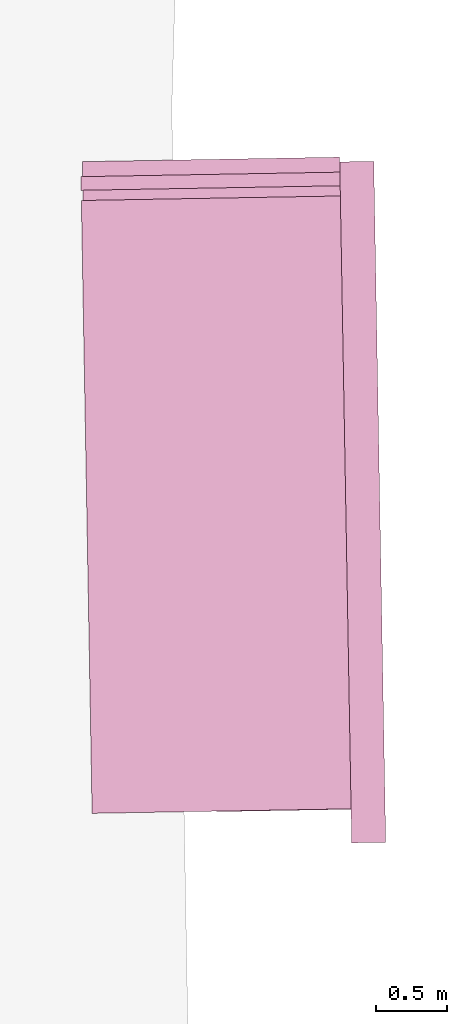
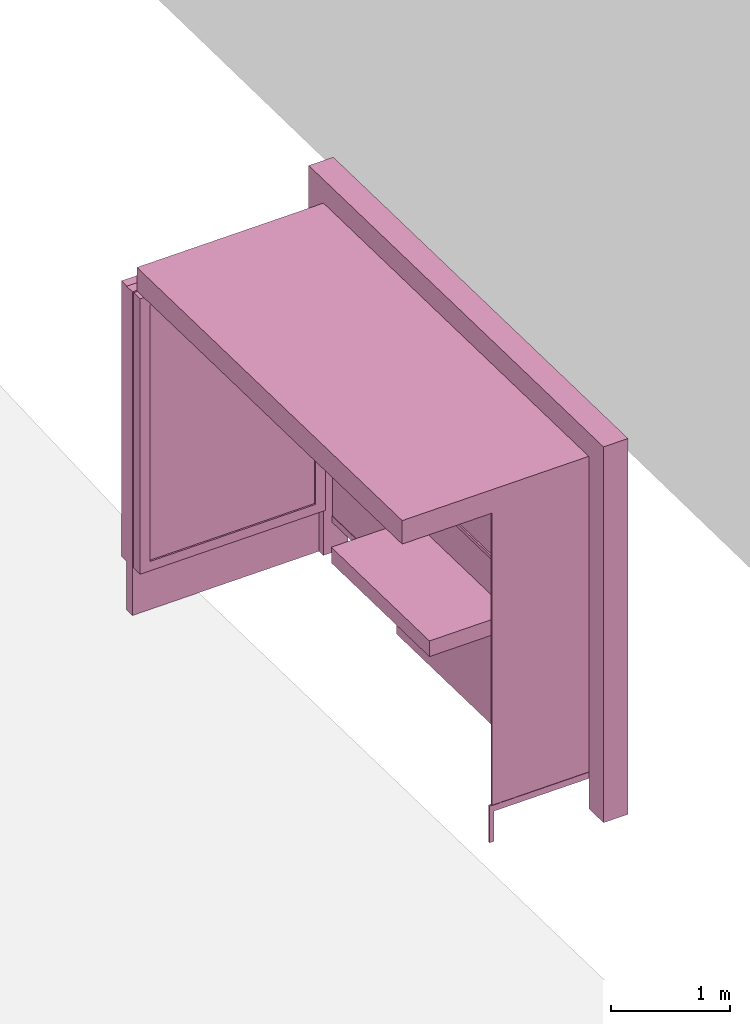
# One storey, part 27 of 200: 1 furnishing.
"""IFC4 building model written with IfcOpenShell, lengths in metres."""

from ifc_helpers import new_model, si_unit, origin_with_axes, place, context, subcontext, project, spatial, triangles, material, element, save


model = new_model("IFC4")

# Units and contexts
model_context = context("Model", 3, precision=1e-05, world=origin_with_axes())
body_context = subcontext(model_context, "Body", "Model", "MODEL_VIEW")
ifc_project = project(units=[si_unit("VOLUMEUNIT", "CUBIC_METRE"), si_unit("LENGTHUNIT", "METRE"), si_unit("AREAUNIT", "SQUARE_METRE")], contexts=[model_context])

# Site, building, storey
site_placement = place(None, origin_with_axes())
site = spatial("IfcSite", under=ifc_project, at=site_placement)
building_placement = place(site_placement, origin_with_axes())
building = spatial("IfcBuilding", under=site, at=building_placement, Name="Building")
storey_placement = place(building_placement, origin_with_axes())
storey = spatial("IfcBuildingStorey", under=building, at=storey_placement, Name="Ground")

# Furnishing
ifc_material = material(Name="busStop")
furnishing_placement = place(storey_placement, origin_with_axes())
element("IfcFurnishingElement", 1, at=furnishing_placement, inside=storey, material=ifc_material, Name="cw_instances_busStop_22", context=body_context, shape_type="Tessellation", body=[
    triangles([(180.32204936237486, -389.8630590428652, 3.3823837170154), (182.47203148521953, -394.1644852282058, 3.3823837170154), (182.3960797844333, -389.8267450546434, 3.3823837170154), (180.39800085740129, -394.2007993968073, 3.3823837170154), (180.32204926598064, -389.86305904455304, 3.623406387340317), (182.4720313888253, -394.16448522989367, 3.623406387340317), (180.39800076100704, -394.2007993984952, 3.623406387340317), (182.3960796880391, -389.8267450563313, 3.623406387340317), (180.32204936237486, -389.8630590428652, 3.3823837170154), (180.39800076100704, -394.2007993984952, 3.623406387340317), (180.39800085740129, -394.2007993968073, 3.3823837170154), (180.32204926598064, -389.86305904455304, 3.623406387340317), (180.39800085740129, -394.2007993968073, 3.3823837170154), (182.4720313888253, -394.16448522989367, 3.623406387340317), (182.47203148521953, -394.1644852282058, 3.3823837170154), (180.39800076100704, -394.2007993984952, 3.623406387340317), (182.47203148521953, -394.1644852282058, 3.3823837170154), (182.3960796880391, -389.8267450563313, 3.623406387340317), (182.3960797844333, -389.8267450546434, 3.3823837170154), (182.4720313888253, -394.16448522989367, 3.623406387340317), (182.3960797844333, -389.8267450546434, 3.3823837170154), (180.32204926598064, -389.86305904455304, 3.623406387340317), (180.32204936237486, -389.8630590428652, 3.3823837170154), (182.3960796880391, -389.8267450563313, 3.623406387340317), (182.15509378013567, -389.8309646539405, 3.864428655961051), (182.39185972401305, -389.58575933162064, 3.864428655961051), (182.39607931852788, -389.8267450628013, 3.864428655961051), (182.15087418562084, -389.5899789227598, 3.864428655961051), (182.15509378013567, -389.8309646539405, 3.623406387340317), (182.15087418562084, -389.5899789227598, 3.864428655961051), (182.15509378013567, -389.8309646539405, 3.864428655961051), (182.15087418562084, -389.5899789227598, 3.623406387340317), (182.23526486292556, -394.4096903534864, 3.623406387340317), (182.47625059410623, -394.40547075897155, 3.864428655961051), (182.47625059410623, -394.40547075897155, 3.623406387340317), (182.23526486292556, -394.4096903534864, 3.864428655961051), (182.4720310032484, -394.164485236645, 3.623406387340317), (182.47625059410623, -394.40547075897155, 3.864428655961051), (182.4720310032484, -394.164485236645, 3.864428655961051), (182.47625059410623, -394.40547075897155, 3.623406387340317), (182.3918599007358, -389.58575932852625, 3.623406387340317), (182.15087418562084, -389.5899789227598, 3.864428655961051), (182.15087418562084, -389.5899789227598, 3.623406387340317), (182.39185972401305, -389.58575933162064, 3.864428655961051), (182.23104546485618, -394.1687048277842, 3.864428655961051), (182.4720310032484, -394.164485236645, 3.864428655961051), (182.23104546485618, -394.1687048277842, 3.623406387340317), (182.23104546485618, -394.1687048277842, 3.864428655961051), (182.3918599007358, -389.58575932852625, 3.623406387340317), (182.39607931852788, -389.8267450628013, 3.864428655961051), (182.39185972401305, -389.58575933162064, 3.864428655961051), (182.39607931852788, -389.8267450628013, 3.623406387340317), (182.23526486292556, -394.4096903534864, 3.864428655961051), (182.47625059410623, -394.40547075897155, 3.864428655961051), (182.23526486292556, -394.4096903534864, 3.623406387340317), (182.23526486292556, -394.4096903534864, 3.864428655961051), (182.39186076828386, -389.58575931333576, 9.480218712634252e-07), (182.15087532628587, -389.5899789027871, 8.998173693347766e-07), (182.3960803627987, -389.82674504451643, 9.480218712634252e-07), (182.39186076828386, -389.58575931333576, 9.480218712634252e-07), (182.39607931852788, -389.8267450628013, 3.623406387340317), (182.15509474407796, -389.8309646370621, 8.998173693347766e-07), (182.15509378013567, -389.8309646539405, 3.623406387340317), (182.3960803627987, -389.82674504451643, 9.480218712634252e-07), (182.15087532628587, -389.5899789027871, 8.998173693347766e-07), (182.15509474407796, -389.8309646370621, 8.998173693347766e-07), (182.23526599293223, -394.4096888069904, 8.998173693347766e-07), (182.47625163837705, -394.40547074068667, 9.480218712634252e-07), (182.23104640179307, -394.16870326859816, 8.998173693347766e-07), (182.23526599293223, -394.4096888069904, 8.998173693347766e-07), (182.23104546485618, -394.1687048277842, 3.623406387340317), (182.4720320205138, -394.1644836760525, 9.480218712634252e-07), (182.4720310032484, -394.164485236645, 3.623406387340317), (182.23104640179307, -394.16870326859816, 8.998173693347766e-07), (182.47625163837705, -394.40547074068667, 9.480218712634252e-07), (182.4720320205138, -394.1644836760525, 9.480218712634252e-07), (181.279848137964, -394.1851094445589, 0.34596862720110877), (182.3258808533353, -394.1667936966244, 3.3823837170154), (182.32588172088333, -394.16679368143383, 0.34596880395094914), (181.27984735074446, -394.1851094583429, 3.3823837170154), (182.32560041505118, -394.150727992798, 0.34596880395094914), (181.27956604491231, -394.169043769707, 3.3823837170154), (181.27956683213185, -394.16904375592304, 0.34596862720110877), (182.32559954750315, -394.1507280079885, 3.3823837170154), (181.27956683213185, -394.16904375592304, 0.34596862720110877), (181.27984735074446, -394.1851094583429, 3.3823837170154), (181.279848137964, -394.1851094445589, 0.34596862720110877), (181.27956604491231, -394.169043769707, 3.3823837170154), (182.325530086835, -394.14671147022835, 0.31383250146818464), (181.27991851100163, -394.18912577349613, 0.3138323086501769), (182.32595204572388, -394.170810011215, 0.31383250146818464), (181.27949655211276, -394.1650272325095, 0.3138323086501769), (182.325530086835, -394.14671147022835, 0.378105122501881), (181.2799184949359, -394.18912577377745, 0.3781049296838733), (181.27949653604705, -394.1650272327908, 0.3781049296838733), (182.32595204572388, -394.170810011215, 0.378105122501881), (182.325530086835, -394.14671147022835, 0.31383250146818464), (181.27949653604705, -394.1650272327908, 0.3781049296838733), (181.27949655211276, -394.1650272325095, 0.3138323086501769), (182.325530086835, -394.14671147022835, 0.378105122501881), (181.27991851100163, -394.18912577349613, 0.3138323086501769), (182.32595204572388, -394.170810011215, 0.378105122501881), (182.32595204572388, -394.170810011215, 0.31383250146818464), (181.2799184949359, -394.18912577377745, 0.3781049296838733), (181.2799184949359, -394.18912577377745, 0.3781049296838733), (181.27949655211276, -394.1650272325095, 0.3138323086501769), (181.27949653604705, -394.1650272327908, 0.3781049296838733), (181.27991851100163, -394.18912577349613, 0.3138323086501769), (181.25743921817025, -394.16914498649095, 0.3781049296838733), (181.30197565418732, -394.1850063032973, 0.3781049296838733), (181.25773051065073, -394.18578102370947, 0.3781049296838733), (181.30168436170686, -394.16837026607885, 0.3781049296838733), (181.25743947522153, -394.1691449819901, 1.446135057859462e-07), (181.25773051065073, -394.18578102370947, 0.3781049296838733), (181.25773076770201, -394.18578101920855, 1.446135057859462e-07), (181.25743921817025, -394.16914498649095, 0.3781049296838733), (181.25773076770201, -394.18578101920855, 1.446135057859462e-07), (181.30197565418732, -394.1850063032973, 0.3781049296838733), (181.30197576664727, -394.1850063013282, 1.606816730954958e-07), (181.25773051065073, -394.18578102370947, 0.3781049296838733), (181.30197576664727, -394.1850063013282, 1.606816730954958e-07), (181.30168436170686, -394.16837026607885, 0.3781049296838733), (181.3016844741668, -394.1683702641097, 1.606816730954958e-07), (181.30197565418732, -394.1850063032973, 0.3781049296838733), (181.3016844741668, -394.1683702641097, 1.606816730954958e-07), (181.25743921817025, -394.16914498649095, 0.3781049296838733), (181.25743947522153, -394.1691449819901, 1.446135057859462e-07), (181.30168436170686, -394.16837026607885, 0.3781049296838733), (182.11214955591205, -391.13838923568755, 1.1247720651681516), (182.29368144399288, -392.7422736912719, 1.1247721615771553), (182.14027968528606, -392.7449597142843, 1.1247720651681516), (182.2655511218304, -391.1357032160509, 1.1247721615771553), (182.14027987807452, -392.74495971090863, 4.98113186596037e-07), (182.11214955591205, -391.13838923568755, 0.9640904563453251), (182.14027968528606, -392.7449597142843, 0.9640904563453251), (182.11214989329184, -391.13838922978016, 4.98113186596037e-07), (182.2936818295698, -392.74227368452057, 5.302495212151362e-07), (182.14027968528606, -392.7449597142843, 0.9640904563453251), (182.29368144399288, -392.7422736912719, 0.9640905527543289), (182.14027987807452, -392.74495971090863, 4.98113186596037e-07), (182.2655515074073, -391.13570320929955, 5.302495212151362e-07), (182.29368144399288, -392.7422736912719, 0.9640905527543289), (182.2655511218304, -391.1357032160509, 0.9640905527543289), (182.2936818295698, -392.74227368452057, 5.302495212151362e-07), (182.11214989329184, -391.13838922978016, 4.98113186596037e-07), (182.2655511218304, -391.1357032160509, 0.9640905527543289), (182.11214955591205, -391.13838923568755, 0.9640904563453251), (182.2655515074073, -391.13570320929955, 5.302495212151362e-07), (181.49765156148587, -392.75621195769713, 1.1247719687591475), (181.46952135178333, -391.14964148050694, 0.9640903599363211), (181.46952131965193, -391.1496414810696, 1.1247719687591475), (181.49765157755158, -392.7562119574158, 0.9640903599363211), (182.29368144399288, -392.7422736912719, 1.1247721615771553), (182.14027968528606, -392.7449597142843, 1.1247720651681516), (182.2655511218304, -391.1357032160509, 1.1247721615771553), (182.29368144399288, -392.7422736912719, 1.1247721615771553), (182.11214955591205, -391.13838923568755, 1.1247720651681516), (182.2655511218304, -391.1357032160509, 1.1247721615771553), (181.46952131965193, -391.1496414810696, 1.1247719687591475), (181.49765156148587, -392.75621195769713, 1.1247719687591475), (181.46952135178333, -391.14964148050694, 0.9640903599363211), (181.46952131965193, -391.1496414810696, 1.1247719687591475), (181.49765156148587, -392.75621195769713, 1.1247719687591475), (181.49765157755158, -392.7562119574158, 0.9640903599363211), (182.23945658003586, -389.6898030603369, 0.34596880395094914), (182.31996210403832, -394.2876777131457, 3.5028950521778586), (182.3199630519149, -394.2876776965486, 0.34596880395094914), (182.23945590527626, -389.68980307215173, 3.5028950521778586), (182.33602875661646, -394.28739639043516, 0.34596880395094914), (182.25552159391214, -389.6895217663196, 3.5028950521778586), (182.2555222686717, -389.68952175450477, 0.34596880395094914), (182.33602779267417, -394.28739640731357, 3.5028950521778586), (182.05416985039662, -389.5738965455137, 0.5809565598614106), (180.4261684049268, -389.6024024073994, 3.219113622848009), (180.42616898329217, -389.60240239727233, 0.5809562706343991), (182.05416923989986, -389.57389655620335, 3.219113622848009), (182.15028277277392, -389.55614302019717, 0.48454753993594585), (180.42588767746003, -389.5863367086365, 0.5809562706343991), (180.32949351892074, -389.5880230173874, 0.48454721857259964), (182.05388854456447, -389.55783085687784, 0.5809565598614106), (180.42588709909467, -389.5863367187635, 3.219113622848009), (180.32949267809676, -389.5880245588199, 3.3155225302963025), (182.05388793406772, -389.5578308675675, 3.219113622848009), (182.15028211408003, -389.5561430317307, 3.3155225302963025), (182.05388854456447, -389.55783085687784, 0.5809565598614106), (180.42616898329217, -389.60240239727233, 0.5809562706343991), (180.42588767746003, -389.5863367086365, 0.5809562706343991), (182.05416985039662, -389.5738965455137, 0.5809565598614106), (180.42588767746003, -389.5863367086365, 0.5809562706343991), (180.4261684049268, -389.6024024073994, 3.219113622848009), (180.42588709909467, -389.5863367187635, 3.219113622848009), (180.42616898329217, -389.60240239727233, 0.5809562706343991), (180.42588709909467, -389.5863367187635, 3.219113622848009), (182.05416923989986, -389.57389655620335, 3.219113622848009), (182.05388793406772, -389.5578308675675, 3.219113622848009), (180.4261684049268, -389.6024024073994, 3.219113622848009), (182.05388793406772, -389.5578308675675, 3.219113622848009), (182.05416985039662, -389.5738965455137, 0.5809565598614106), (182.05388854456447, -389.55783085687784, 0.5809565598614106), (182.05416923989986, -389.57389655620335, 3.219113622848009), (180.334897186847, -389.89668205855605, 3.3155225302963025), (182.15028211408003, -389.5561430317307, 3.3155225302963025), (182.1556863336476, -389.8648005365304, 3.3155225302963025), (180.32949267809676, -389.5880245588199, 3.3155225302963025), (180.33489805439507, -389.89668204336556, 0.48454721857259964), (180.32949267809676, -389.5880245588199, 3.3155225302963025), (180.334897186847, -389.89668205855605, 3.3155225302963025), (180.32949351892074, -389.5880230173874, 0.48454721857259964), (182.15028277277392, -389.55614302019717, 0.48454753993594585), (182.1556863336476, -389.8648005365304, 3.3155225302963025), (182.15028211408003, -389.5561430317307, 3.3155225302963025), (182.15568710480142, -389.8648005230277, 0.48454753993594585), (182.05901160289125, -389.85042267050994, 0.5809565598614106), (180.43101030201277, -389.8789285298638, 3.219113622848009), (182.059010799606, -389.8504226845752, 3.219113622848009), (180.43101088037812, -389.8789285197368, 0.5809562706343991), (182.15568710480142, -389.8648005230277, 0.48454753993594585), (180.43129218621027, -389.8949942083727, 0.5809562706343991), (182.0592929087234, -389.8664883591458, 0.5809565598614106), (180.33489805439507, -389.89668204336556, 0.48454721857259964), (180.4312916078449, -389.8949942184997, 3.219113622848009), (180.334897186847, -389.89668205855605, 3.3155225302963025), (182.05929210543815, -389.8664883732111, 3.219113622848009), (182.1556863336476, -389.8648005365304, 3.3155225302963025), (182.0592929087234, -389.8664883591458, 0.5809565598614106), (180.43101088037812, -389.8789285197368, 0.5809562706343991), (182.05901160289125, -389.85042267050994, 0.5809565598614106), (180.43129218621027, -389.8949942083727, 0.5809562706343991), (180.43129218621027, -389.8949942083727, 0.5809562706343991), (180.43101030201277, -389.8789285298638, 3.219113622848009), (180.43101088037812, -389.8789285197368, 0.5809562706343991), (180.4312916078449, -389.8949942184997, 3.219113622848009), (180.4312916078449, -389.8949942184997, 3.219113622848009), (182.059010799606, -389.8504226845752, 3.219113622848009), (180.43101030201277, -389.8789285298638, 3.219113622848009), (182.05929210543815, -389.8664883732111, 3.219113622848009), (182.05929210543815, -389.8664883732111, 3.219113622848009), (182.05901160289125, -389.85042267050994, 0.5809565598614106), (182.059010799606, -389.8504226845752, 3.219113622848009), (182.0592929087234, -389.8664883591458, 0.5809565598614106), (180.31909567772075, -389.69437083039765, 3.328512133158346), (182.1538282859516, -389.7586688475064, 3.328512133158346), (180.32078348598955, -389.790763435971, 3.328512133158346), (182.1521404509587, -389.6622747156912, 3.328512133158346), (180.3190963223806, -389.69436909955243, 0.0), (180.32078348598955, -389.790763435971, 3.328512133158346), (180.32078416074916, -389.79076342415607, 0.0), (180.31909567772075, -389.69437083039765, 3.328512133158346), (180.32078416074916, -389.79076342415607, 0.0), (182.1538282859516, -389.7586688475064, 3.328512133158346), (182.15382904103973, -389.758668834285, 5.141813539055866e-07), (180.32078348598955, -389.790763435971, 3.328512133158346), (182.15382904103973, -389.758668834285, 5.141813539055866e-07), (182.1521404509587, -389.6622747156912, 3.328512133158346), (182.15214120604685, -389.6622747024698, 5.141813539055866e-07), (182.1538282859516, -389.7586688475064, 3.328512133158346), (182.15214120604685, -389.6622747024698, 5.141813539055866e-07), (180.31909567772075, -389.69437083039765, 3.328512133158346), (180.3190963223806, -389.69436909955243, 0.0), (182.1521404509587, -389.6622747156912, 3.328512133158346), (182.23544015386045, -389.68987338686526, 0.31383250146818464), (182.33830344464042, -394.1878488737557, 0.31383250146818464), (182.25953879124134, -389.68945142628854, 0.31383250146818464), (182.31420491971946, -394.1882708323633, 0.31383250146818464), (182.23544015386045, -389.68987338686526, 0.378105122501881), (182.33830344464042, -394.1878488737557, 0.378105122501881), (182.31420491971946, -394.1882708323633, 0.378105122501881), (182.25953879124134, -389.68945142628854, 0.378105122501881), (182.23544015386045, -389.68987338686526, 0.31383250146818464), (182.31420491971946, -394.1882708323633, 0.378105122501881), (182.31420491971946, -394.1882708323633, 0.31383250146818464), (182.23544015386045, -389.68987338686526, 0.378105122501881), (182.33830344464042, -394.1878488737557, 0.31383250146818464), (182.25953879124134, -389.68945142628854, 0.378105122501881), (182.25953879124134, -389.68945142628854, 0.31383250146818464), (182.33830344464042, -394.1878488737557, 0.378105122501881), (182.2674541977584, -391.29637667877864, 1.5289466322217304), (182.28995801235624, -392.58163308278523, 2.8143998402358568), (182.2674538121815, -391.29637668553, 2.8143998402358568), (182.28995839793313, -392.5816330760339, 1.5289466322217304), (182.25451257332554, -391.32874455975815, 1.5610831275225028), (182.27589117897267, -392.5497381125457, 2.7822635377530918), (182.27589174127232, -392.54973810269996, 1.5610831275225028), (182.25451238053708, -391.3287445631338, 2.7822635377530918), (182.2674541977584, -391.29637667877864, 1.5289466322217304), (182.2603884723562, -392.5821508373767, 1.5289466322217304), (182.28995839793313, -392.5816330760339, 1.5289466322217304), (182.2378844649699, -391.2968944367458, 1.5289466322217304), (182.28995839793313, -392.5816330760339, 1.5289466322217304), (182.26038829563345, -392.582150840471, 2.8143998402358568), (182.28995801235624, -392.58163308278523, 2.8143998402358568), (182.2603884723562, -392.5821508373767, 1.5289466322217304), (182.28995801235624, -392.58163308278523, 2.8143998402358568), (182.237884079393, -391.29689444349714, 2.8143998402358568), (182.2674538121815, -391.29637668553, 2.8143998402358568), (182.26038829563345, -392.582150840471, 2.8143998402358568), (182.2674538121815, -391.29637668553, 2.8143998402358568), (182.2378844649699, -391.2968944367458, 1.5289466322217304), (182.2674541977584, -391.29637667877864, 1.5289466322217304), (182.237884079393, -391.29689444349714, 2.8143998402358568), (182.29652808870148, -392.9568354154693, 1.5289466322217304), (182.31059262490805, -393.760120760445, 2.8143998402358568), (182.29652751202394, -392.9568355219905, 2.8143998402358568), (182.31059301048498, -393.7601207536936, 1.5289466322217304), (182.28358665958882, -392.98920343766446, 1.5610831275225028), (182.2965260815511, -393.7282258333391, 2.7822635377530918), (182.29652637073377, -393.7282258282755, 1.5610831275225028), (182.28358609728915, -392.9892034475102, 2.7822635377530918), (182.29652808870148, -392.9568354154693, 1.5289466322217304), (182.2810232937622, -393.76063851137945, 1.5289466322217304), (182.31059301048498, -393.7601207536936, 1.5289466322217304), (182.26695816312454, -392.9573531768121, 1.5289466322217304), (182.31059301048498, -393.7601207536936, 1.5289466322217304), (182.2810229081853, -393.7606385181308, 2.8143998402358568), (182.31059262490805, -393.760120760445, 2.8143998402358568), (182.2810232937622, -393.76063851137945, 1.5289466322217304), (182.31059262490805, -393.760120760445, 2.8143998402358568), (182.26695779530115, -392.95735327967634, 2.8143998402358568), (182.29652751202394, -392.9568355219905, 2.8143998402358568), (182.2810229081853, -393.7606385181308, 2.8143998402358568), (182.29652751202394, -392.9568355219905, 2.8143998402358568), (182.26695816312454, -392.9573531768121, 1.5289466322217304), (182.29652808870148, -392.9568354154693, 1.5289466322217304), (182.26695779530115, -392.95735327967634, 2.8143998402358568), (182.2378844649699, -391.2968944367458, 1.5289466322217304), (182.25982595624222, -392.55001941022, 1.5610831275225028), (182.2603884723562, -392.5821508373767, 1.5289466322217304), (182.23844707747813, -391.3290258622146, 1.5610831275225028), (182.25982568312526, -392.55001941500217, 2.7822635377530918), (182.26038829563345, -392.582150840471, 2.8143998402358568), (182.2384466919012, -391.32902586896597, 2.7822635377530918), (182.237884079393, -391.29689444349714, 2.8143998402358568), (182.26695816312454, -392.9573531768121, 1.5289466322217304), (182.2804606820979, -393.7285071341077, 1.5610831275225028), (182.2810232937622, -393.76063851137945, 1.5289466322217304), (182.26752077816448, -392.9894847468723, 1.5610831275225028), (182.280460296521, -393.72850714085905, 2.7822635377530918), (182.2810229081853, -393.7606385181308, 2.8143998402358568), (182.2675204086533, -392.9894847533423, 2.7822635377530918), (182.26695779530115, -392.95735327967634, 2.8143998402358568), (182.23844707747813, -391.3290258622146, 1.5610831275225028), (182.27589174127232, -392.54973810269996, 1.5610831275225028), (182.25982595624222, -392.55001941022, 1.5610831275225028), (182.25451257332554, -391.32874455975815, 1.5610831275225028), (182.25982595624222, -392.55001941022, 1.5610831275225028), (182.27589117897267, -392.5497381125457, 2.7822635377530918), (182.25982568312526, -392.55001941500217, 2.7822635377530918), (182.27589174127232, -392.54973810269996, 1.5610831275225028), (182.25982568312526, -392.55001941500217, 2.7822635377530918), (182.25451238053708, -391.3287445631338, 2.7822635377530918), (182.2384466919012, -391.32902586896597, 2.7822635377530918), (182.27589117897267, -392.5497381125457, 2.7822635377530918), (182.2384466919012, -391.32902586896597, 2.7822635377530918), (182.25451257332554, -391.32874455975815, 1.5610831275225028), (182.23844707747813, -391.3290258622146, 1.5610831275225028), (182.25451238053708, -391.3287445631338, 2.7822635377530918), (182.26752077816448, -392.9894847468723, 1.5610831275225028), (182.29652637073377, -393.7282258282755, 1.5610831275225028), (182.2804606820979, -393.7285071341077, 1.5610831275225028), (182.28358665958882, -392.98920343766446, 1.5610831275225028), (182.2804606820979, -393.7285071341077, 1.5610831275225028), (182.2965260815511, -393.7282258333391, 2.7822635377530918), (182.280460296521, -393.72850714085905, 2.7822635377530918), (182.29652637073377, -393.7282258282755, 1.5610831275225028), (182.280460296521, -393.72850714085905, 2.7822635377530918), (182.28358609728915, -392.9892034475102, 2.7822635377530918), (182.2675204086533, -392.9894847533423, 2.7822635377530918), (182.2965260815511, -393.7282258333391, 2.7822635377530918), (182.2675204086533, -392.9894847533423, 2.7822635377530918), (182.28358665958882, -392.98920343766446, 1.5610831275225028), (182.26752077816448, -392.9894847468723, 1.5610831275225028), (182.28358609728915, -392.9892034475102, 2.7822635377530918)], [[1, 3, 2], [2, 4, 1], [5, 7, 6], [6, 8, 5], [9, 11, 10], [10, 12, 9], [13, 15, 14], [14, 16, 13], [17, 19, 18], [18, 20, 17], [21, 23, 22], [22, 24, 21], [25, 27, 26], [26, 28, 25], [29, 31, 30], [30, 32, 29], [33, 35, 34], [34, 36, 33], [37, 39, 38], [38, 40, 37], [41, 43, 42], [42, 44, 41], [45, 46, 27], [27, 25, 45], [47, 48, 31], [31, 29, 47], [49, 51, 50], [50, 52, 49], [52, 50, 39], [39, 37, 52], [53, 54, 46], [46, 45, 53], [55, 56, 48], [48, 47, 55], [43, 41, 57], [57, 58, 43], [49, 52, 59], [59, 60, 49], [61, 63, 62], [62, 64, 61], [29, 32, 65], [65, 66, 29], [35, 33, 67], [67, 68, 35], [55, 47, 69], [69, 70, 55], [71, 73, 72], [72, 74, 71], [37, 40, 75], [75, 76, 37], [77, 79, 78], [78, 80, 77], [81, 83, 82], [82, 84, 81], [85, 87, 86], [86, 88, 85], [89, 91, 90], [90, 92, 89], [93, 95, 94], [94, 96, 93], [97, 99, 98], [98, 100, 97], [101, 103, 102], [102, 104, 101], [105, 107, 106], [106, 108, 105], [109, 111, 110], [110, 112, 109], [113, 115, 114], [114, 116, 113], [117, 119, 118], [118, 120, 117], [121, 123, 122], [122, 124, 121], [125, 127, 126], [126, 128, 125], [129, 131, 130], [130, 132, 129], [133, 135, 134], [134, 136, 133], [137, 139, 138], [138, 140, 137], [141, 143, 142], [142, 144, 141], [145, 147, 146], [146, 148, 145], [149, 151, 150], [150, 152, 149], [153, 154, 138], [138, 139, 153], [155, 156, 142], [142, 143, 155], [157, 158, 146], [146, 147, 157], [131, 129, 159], [159, 160, 131], [157, 147, 161], [161, 162, 157], [138, 154, 163], [163, 164, 138], [165, 167, 166], [166, 168, 165], [169, 171, 170], [170, 172, 169], [173, 175, 174], [174, 176, 173], [177, 179, 178], [178, 180, 177], [179, 182, 181], [181, 178, 179], [182, 184, 183], [183, 181, 182], [184, 177, 180], [180, 183, 184], [185, 187, 186], [186, 188, 185], [189, 191, 190], [190, 192, 189], [193, 195, 194], [194, 196, 193], [197, 199, 198], [198, 200, 197], [201, 203, 202], [202, 204, 201], [205, 207, 206], [206, 208, 205], [209, 211, 210], [210, 212, 209], [213, 215, 214], [214, 216, 213], [217, 219, 218], [218, 220, 217], [220, 218, 221], [221, 222, 220], [222, 221, 223], [223, 224, 222], [224, 223, 219], [219, 217, 224], [225, 227, 226], [226, 228, 225], [229, 231, 230], [230, 232, 229], [233, 235, 234], [234, 236, 233], [237, 239, 238], [238, 240, 237], [241, 243, 242], [242, 244, 241], [245, 247, 246], [246, 248, 245], [249, 251, 250], [250, 252, 249], [253, 255, 254], [254, 256, 253], [257, 259, 258], [258, 260, 257], [261, 263, 262], [262, 264, 261], [265, 267, 266], [266, 268, 265], [269, 271, 270], [270, 272, 269], [273, 275, 274], [274, 276, 273], [277, 279, 278], [278, 280, 277], [281, 283, 282], [282, 284, 281], [285, 287, 286], [286, 288, 285], [289, 291, 290], [290, 292, 289], [293, 295, 294], [294, 296, 293], [297, 299, 298], [298, 300, 297], [301, 303, 302], [302, 304, 301], [305, 307, 306], [306, 308, 305], [309, 311, 310], [310, 312, 309], [313, 315, 314], [314, 316, 313], [317, 319, 318], [318, 320, 317], [321, 323, 322], [322, 324, 321], [325, 327, 326], [326, 328, 325], [327, 330, 329], [329, 326, 327], [330, 332, 331], [331, 329, 330], [332, 325, 328], [328, 331, 332], [333, 335, 334], [334, 336, 333], [335, 338, 337], [337, 334, 335], [338, 340, 339], [339, 337, 338], [340, 333, 336], [336, 339, 340], [341, 343, 342], [342, 344, 341], [345, 347, 346], [346, 348, 345], [349, 351, 350], [350, 352, 349], [353, 355, 354], [354, 356, 353], [357, 359, 358], [358, 360, 357], [361, 363, 362], [362, 364, 361], [365, 367, 366], [366, 368, 365], [369, 371, 370], [370, 372, 369]], closed=True),
])

save(model, "model.ifc")
